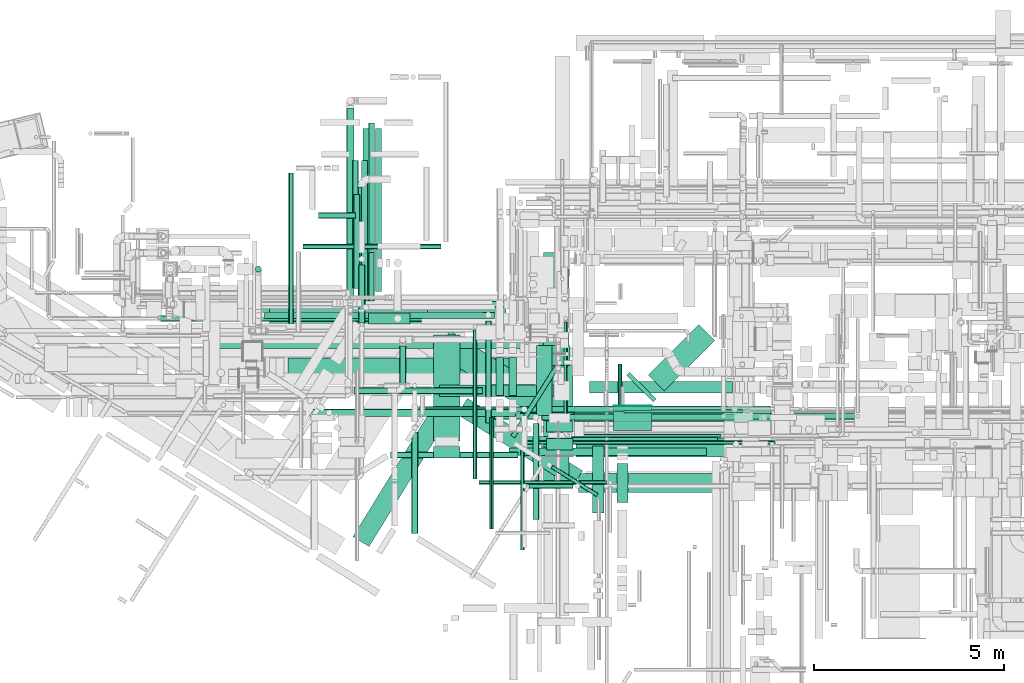
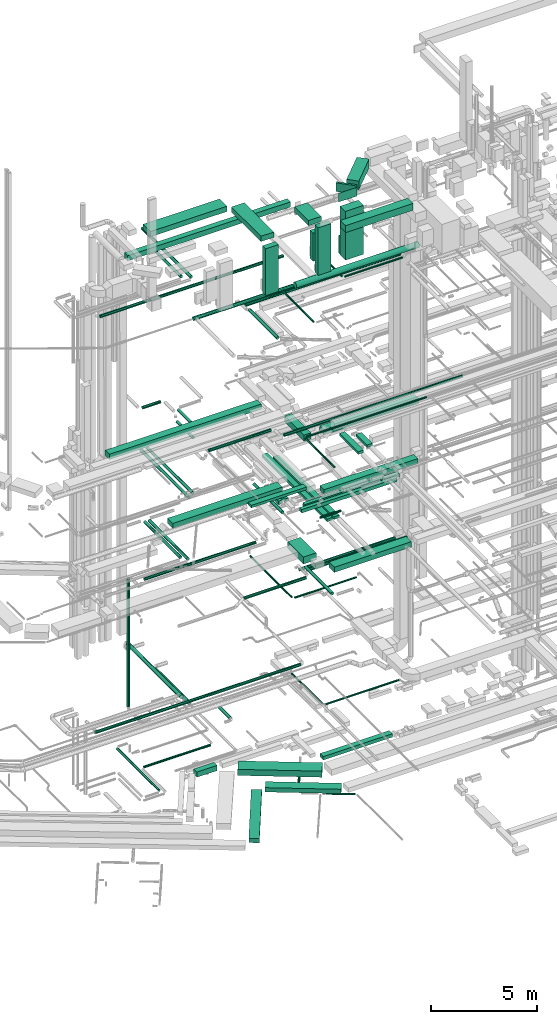
# One storey, part 28 of 337: 75 flow segments.
"""IFC2X3 building model written with IfcOpenShell, lengths in millimetres."""

from ifc_helpers import new_model, entity, si_unit, converted_unit, derived_unit, direction, frame, origin, origin_2d_with_axis, place, context, subcontext, project, spatial, rectangle, circle, extrude, type_object, element, save


model = new_model("IFC2X3")

# Units and contexts
model_context = context("Model", 3, precision=0.01, world=origin(), true_north=direction((6.12303176911189e-17, 1.0)))
body_context = subcontext(model_context, "Body", "Model", "MODEL_VIEW")
ifc_project = project(units=[si_unit("LENGTHUNIT", "METRE", prefix="MILLI"), si_unit("AREAUNIT", "SQUARE_METRE"), si_unit("VOLUMEUNIT", "CUBIC_METRE"), converted_unit("PLANEANGLEUNIT", "DEGREE", entity("IfcRatioMeasure", 0.0174532925199433), si_unit("PLANEANGLEUNIT", "RADIAN"), dimensions=[0, 0, 0, 0, 0, 0, 0]), si_unit("MASSUNIT", "GRAM", prefix="KILO"), derived_unit("MASSDENSITYUNIT", [(si_unit("MASSUNIT", "GRAM", prefix="KILO"), 1), (si_unit("LENGTHUNIT", "METRE"), -3)]), derived_unit("MOMENTOFINERTIAUNIT", [(si_unit("LENGTHUNIT", "METRE"), 4)]), si_unit("TIMEUNIT", "SECOND"), si_unit("FREQUENCYUNIT", "HERTZ"), si_unit("THERMODYNAMICTEMPERATUREUNIT", "DEGREE_CELSIUS"), derived_unit("THERMALTRANSMITTANCEUNIT", [(si_unit("MASSUNIT", "GRAM", prefix="KILO"), 1), (si_unit("THERMODYNAMICTEMPERATUREUNIT", "KELVIN"), -1), (si_unit("TIMEUNIT", "SECOND"), -3)]), derived_unit("VOLUMETRICFLOWRATEUNIT", [(si_unit("LENGTHUNIT", "METRE"), 3), (si_unit("TIMEUNIT", "SECOND"), -1)]), derived_unit("MASSFLOWRATEUNIT", [(si_unit("MASSUNIT", "GRAM", prefix="KILO"), 1), (si_unit("TIMEUNIT", "SECOND"), -1)]), derived_unit("ROTATIONALFREQUENCYUNIT", [(si_unit("TIMEUNIT", "SECOND"), -1)]), si_unit("ELECTRICCURRENTUNIT", "AMPERE"), si_unit("ELECTRICVOLTAGEUNIT", "VOLT"), si_unit("POWERUNIT", "WATT"), si_unit("FORCEUNIT", "NEWTON", prefix="KILO"), si_unit("ILLUMINANCEUNIT", "LUX"), si_unit("LUMINOUSFLUXUNIT", "LUMEN"), si_unit("LUMINOUSINTENSITYUNIT", "CANDELA"), derived_unit("USERDEFINED", [(si_unit("MASSUNIT", "GRAM", prefix="KILO"), -1), (si_unit("LENGTHUNIT", "METRE"), -2), (si_unit("TIMEUNIT", "SECOND"), 3), (si_unit("LUMINOUSFLUXUNIT", "LUMEN"), 1)]), derived_unit("LINEARVELOCITYUNIT", [(si_unit("LENGTHUNIT", "METRE"), 1), (si_unit("TIMEUNIT", "SECOND"), -1)]), si_unit("PRESSUREUNIT", "PASCAL"), derived_unit("USERDEFINED", [(si_unit("LENGTHUNIT", "METRE"), -2), (si_unit("MASSUNIT", "GRAM", prefix="KILO"), 1), (si_unit("TIMEUNIT", "SECOND"), -2)]), derived_unit("LINEARFORCEUNIT", [(si_unit("MASSUNIT", "GRAM", prefix="KILO"), 1), (si_unit("LENGTHUNIT", "METRE"), 1), (si_unit("TIMEUNIT", "SECOND"), -2), (si_unit("LENGTHUNIT", "METRE"), -1)]), derived_unit("PLANARFORCEUNIT", [(si_unit("MASSUNIT", "GRAM", prefix="KILO"), 1), (si_unit("LENGTHUNIT", "METRE"), 1), (si_unit("TIMEUNIT", "SECOND"), -2), (si_unit("LENGTHUNIT", "METRE"), -2)])], contexts=[model_context])

# Site, building, storey
site_placement = place(None, origin())
site = spatial("IfcSite", under=ifc_project, at=site_placement, CompositionType="ELEMENT")
building_placement = place(site_placement, origin())
building = spatial("IfcBuilding", under=site, at=building_placement, CompositionType="ELEMENT")
storey_placement = place(building_placement, origin())
storey = spatial("IfcBuildingStorey", under=building, at=storey_placement, CompositionType="ELEMENT", Elevation=0.0)

# Flow segments
duct_segment_type_1 = type_object("IfcDuctSegmentType", PredefinedType="NOTDEFINED")
flow_segment_1_placement = place(storey_placement, frame((15204.03, 9600.54, -800.0)))
element("IfcFlowSegment", 1, at=flow_segment_1_placement, inside=storey, type_object=duct_segment_type_1, context=body_context, shape_type="SweptSolid", body=[
    extrude(rectangle(XDim=3972.83667806784, YDim=700.0, at=origin_2d_with_axis()), frame((1867.74, 1354.02, 0.0), z_axis=(0.0, 0.0, 1.0), x_axis=(-0.84642893008142, 0.532501705463206, 0.0)), (0.0, 0.0, 1.0), 350.0),
])
flow_segment_2_placement = place(storey_placement, frame((13426.2, 12483.83, -750.0)))
element("IfcFlowSegment", 2, at=flow_segment_2_placement, inside=storey, type_object=duct_segment_type_1, context=body_context, shape_type="SweptSolid", body=[
    extrude(rectangle(XDim=1097.78533008796, YDim=300.000000000001, at=origin_2d_with_axis()), frame((548.9, 150.02, 0.0)), (0.0, 0.0, 1.0), 300.0),
])
flow_segment_3_placement = place(storey_placement, frame((15769.81, 8199.71, -975.0)))
element("IfcFlowSegment", 3, at=flow_segment_3_placement, inside=storey, type_object=duct_segment_type_1, context=body_context, shape_type="SweptSolid", body=[
    extrude(rectangle(XDim=3583.77962437014, YDim=500.000000000001, at=origin_2d_with_axis()), frame((1649.83, 1165.79, 0.0), z_axis=(0.0, 0.0, 1.0), x_axis=(-0.846428930081417, 0.532501705463211, 0.0)), (0.0, 0.0, 1.0), 250.0),
])
flow_segment_4_placement = place(storey_placement, frame((18041.81, 10437.88, 11150.0)))
element("IfcFlowSegment", 4, at=flow_segment_4_placement, inside=storey, type_object=duct_segment_type_1, context=body_context, shape_type="SweptSolid", body=[
    extrude(rectangle(XDim=1480.0000000004, YDim=700.000000000001, at=origin_2d_with_axis()), frame((350.0, 740.0, 0.0), z_axis=(0.0, 0.0, 1.0), x_axis=(0.0, -1.0, 0.0)), (0.0, 0.0, 1.0), 400.0),
])
flow_segment_5_placement = place(storey_placement, frame((18891.81, 8987.88, 11250.0)))
element("IfcFlowSegment", 5, at=flow_segment_5_placement, inside=storey, type_object=duct_segment_type_1, context=body_context, shape_type="SweptSolid", body=[
    extrude(rectangle(XDim=4200.00000000013, YDim=500.0, at=origin_2d_with_axis()), frame((2100.0, 250.0, 0.0)), (0.0, 0.0, 1.0), 300.000000000001),
])
flow_segment_6_placement = place(storey_placement, frame((18870.0, 9924.94, 15150.0)))
element("IfcFlowSegment", 6, at=flow_segment_6_placement, inside=storey, type_object=duct_segment_type_1, context=body_context, shape_type="SweptSolid", body=[
    extrude(rectangle(XDim=5109.29869136261, YDim=400.0, at=origin_2d_with_axis()), frame((2554.65, 200.0, 0.0)), (0.0, 0.0, 1.0), 300.000000000001),
])
flow_segment_7_placement = place(storey_placement, frame((15292.89, 10584.63, 15250.0)))
element("IfcFlowSegment", 7, at=flow_segment_7_placement, inside=storey, type_object=duct_segment_type_1, context=body_context, shape_type="SweptSolid", body=[
    extrude(rectangle(XDim=3007.10674455727, YDim=300.000000000001, at=origin_2d_with_axis()), frame((1503.55, 150.0, 0.0)), (0.0, 0.0, 1.0), 150.000000000001),
])
flow_segment_8_placement = place(storey_placement, frame((18044.75, 8212.59, 14925.0)))
element("IfcFlowSegment", 8, at=flow_segment_8_placement, inside=storey, type_object=duct_segment_type_1, context=body_context, shape_type="SweptSolid", body=[
    extrude(rectangle(XDim=6156.31853855022, YDim=300.000000000001, at=origin_2d_with_axis()), frame((150.0, 3078.16, 0.0), z_axis=(0.0, 0.0, 1.0), x_axis=(0.0, -1.0, 0.0)), (0.0, 0.0, 1.0), 150.000000000001),
])
flow_segment_9_placement = place(storey_placement, frame((18416.63, 8215.15, 14925.0)))
element("IfcFlowSegment", 9, at=flow_segment_9_placement, inside=storey, type_object=duct_segment_type_1, context=body_context, shape_type="SweptSolid", body=[
    extrude(rectangle(XDim=5728.76050698935, YDim=299.999999999999, at=origin_2d_with_axis()), frame((150.0, 2864.38, 0.0), z_axis=(0.0, 0.0, 1.0), x_axis=(0.0, 1.0, 0.0)), (0.0, 0.0, 1.0), 150.000000000001),
])
flow_segment_10_placement = place(storey_placement, frame((8774.52, 12678.06, 19050.0)))
element("IfcFlowSegment", 10, at=flow_segment_10_placement, inside=storey, type_object=duct_segment_type_1, context=body_context, shape_type="SweptSolid", body=[
    extrude(rectangle(XDim=8275.73593128809, YDim=400.0, at=origin_2d_with_axis()), frame((4137.87, 200.0, 0.0), z_axis=(0.0, 0.0, 1.0), x_axis=(-1.0, 0.0, 0.0)), (0.0, 0.0, 1.0), 300.000000000001),
])
flow_segment_11_placement = place(storey_placement, frame((17859.23, 10075.31, 18500.0)))
element("IfcFlowSegment", 11, at=flow_segment_11_placement, inside=storey, type_object=duct_segment_type_1, context=body_context, shape_type="SweptSolid", body=[
    extrude(rectangle(XDim=1842.09999999976, YDim=400.0, at=origin_2d_with_axis()), frame((200.0, 921.05, 0.0), z_axis=(0.0, 0.0, 1.0), x_axis=(0.0, -1.0, 0.0)), (0.0, 0.0, 1.0), 349.999999999998),
])
flow_segment_12_placement = place(storey_placement, frame((19970.04, 7790.46, 18775.0)))
element("IfcFlowSegment", 12, at=flow_segment_12_placement, inside=storey, type_object=duct_segment_type_1, context=body_context, shape_type="SweptSolid", body=[
    extrude(rectangle(XDim=1026.9595086912, YDim=300.000000000001, at=origin_2d_with_axis()), frame((150.0, 513.48, 0.0), z_axis=(0.0, 0.0, 1.0), x_axis=(0.0, -1.0, 0.0)), (0.0, 0.0, 1.0), 150.000000000001),
])
flow_segment_13_placement = place(storey_placement, frame((18849.92, 9925.3, 18600.0)))
element("IfcFlowSegment", 13, at=flow_segment_13_placement, inside=storey, type_object=duct_segment_type_1, context=body_context, shape_type="SweptSolid", body=[
    extrude(rectangle(XDim=5165.62500000007, YDim=400.0, at=origin_2d_with_axis()), frame((2582.81, 200.0, 0.0)), (0.0, 0.0, 1.0), 300.000000000001),
])
flow_segment_14_placement = place(storey_placement, frame((17480.0, 9320.0, 15250.0)))
element("IfcFlowSegment", 14, at=flow_segment_14_placement, inside=storey, type_object=duct_segment_type_1, context=body_context, shape_type="SweptSolid", body=[
    extrude(rectangle(XDim=5147.55337189572, YDim=200.0, at=origin_2d_with_axis()), frame((2573.78, 100.0, 0.0), z_axis=(0.0, 0.0, 1.0), x_axis=(-1.0, 0.0, 0.0)), (0.0, 0.0, 1.0), 200.000000000002),
])
flow_segment_15_placement = place(storey_placement, frame((17134.94, 9028.26, 15250.0)))
element("IfcFlowSegment", 15, at=flow_segment_15_placement, inside=storey, type_object=duct_segment_type_1, context=body_context, shape_type="SweptSolid", body=[
    extrude(rectangle(XDim=5197.61846850479, YDim=200.0, at=origin_2d_with_axis()), frame((2598.81, 100.0, 0.0), z_axis=(0.0, 0.0, 1.0), x_axis=(-1.0, 0.0, 0.0)), (0.0, 0.0, 1.0), 200.000000000002),
])
flow_segment_16_placement = place(storey_placement, frame((19331.36, 7509.06, 18780.0)))
element("IfcFlowSegment", 16, at=flow_segment_16_placement, inside=storey, type_object=duct_segment_type_1, context=body_context, shape_type="SweptSolid", body=[
    extrude(rectangle(XDim=1766.02500000003, YDim=300.000000000001, at=origin_2d_with_axis()), frame((150.0, 883.01, 0.0), z_axis=(0.0, 0.0, 1.0), x_axis=(0.0, -1.0, 0.0)), (0.0, 0.0, 1.0), 150.000000000001),
])
flow_segment_17_placement = place(storey_placement, frame((11309.44, 11089.53, 15150.0)))
element("IfcFlowSegment", 17, at=flow_segment_17_placement, inside=storey, type_object=duct_segment_type_1, context=body_context, shape_type="SweptSolid", body=[
    extrude(rectangle(XDim=5965.56086231066, YDim=499.999999999999, at=origin_2d_with_axis()), frame((2982.78, 250.0, 0.0)), (0.0, 0.0, 1.0), 300.000000000001),
])
flow_segment_18_placement = place(storey_placement, frame((17130.0, 10607.55, 14900.0)))
element("IfcFlowSegment", 18, at=flow_segment_18_placement, inside=storey, type_object=duct_segment_type_1, context=body_context, shape_type="SweptSolid", body=[
    extrude(rectangle(XDim=997.150594281624, YDim=200.0, at=origin_2d_with_axis()), frame((100.0, 498.58, 0.0), z_axis=(0.0, 0.0, 1.0), x_axis=(0.0, -1.0, 0.0)), (0.0, 0.0, 1.0), 200.000000000002),
])
flow_segment_19_placement = place(storey_placement, frame((16784.94, 10611.81, 14900.0)))
element("IfcFlowSegment", 19, at=flow_segment_19_placement, inside=storey, type_object=duct_segment_type_1, context=body_context, shape_type="SweptSolid", body=[
    extrude(rectangle(XDim=992.893231441465, YDim=200.0, at=origin_2d_with_axis()), frame((100.0, 496.45, 0.0), z_axis=(0.0, 0.0, 1.0), x_axis=(0.0, -1.0, 0.0)), (0.0, 0.0, 1.0), 200.000000000002),
])
flow_segment_20_placement = place(storey_placement, frame((13017.82, 6624.99, -975.0)))
element("IfcFlowSegment", 20, at=flow_segment_20_placement, inside=storey, type_object=duct_segment_type_1, context=body_context, shape_type="SweptSolid", body=[
    extrude(rectangle(XDim=4035.85371403088, YDim=500.0, at=origin_2d_with_axis()), frame((1272.23, 1848.69, 0.0), z_axis=(0.0, 0.0, 1.0), x_axis=(0.525021755454614, 0.851088806352989, 0.0)), (0.0, 0.0, 1.0), 250.0),
])
flow_segment_21_placement = place(storey_placement, frame((19255.54, 10670.0, -700.0)))
element("IfcFlowSegment", 21, at=flow_segment_21_placement, inside=storey, type_object=duct_segment_type_1, context=body_context, shape_type="SweptSolid", body=[
    extrude(rectangle(XDim=3767.66742285411, YDim=300.000000000001, at=origin_2d_with_axis()), frame((1883.83, 150.0, 0.0)), (0.0, 0.0, 1.0), 200.0),
])
duct_segment_type_2 = type_object("IfcDuctSegmentType", PredefinedType="NOTDEFINED")
flow_segment_22_placement = place(storey_placement, frame((17176.46, 9485.25, -1164.1)))
element("IfcFlowSegment", 22, at=flow_segment_22_placement, inside=storey, type_object=duct_segment_type_2, context=body_context, shape_type="SweptSolid", body=[
    extrude(circle(Radius=62.5, at=origin_2d_with_axis()), frame((54.5, 34.88, 64.1), z_axis=(0.532501705463204, 0.846428930081421, 0.0), x_axis=(-0.846428930081421, 0.532501705463204, 0.0)), (0.0, 0.0, 1.0), 2181.26326903953),
])
flow_segment_23_placement = place(storey_placement, frame((18237.11, 7937.9, -1151.6)))
element("IfcFlowSegment", 23, at=flow_segment_23_placement, inside=storey, type_object=duct_segment_type_2, context=body_context, shape_type="SweptSolid", body=[
    extrude(circle(Radius=50.0, at=origin_2d_with_axis()), frame((1218.92, 44.0, 51.6), z_axis=(-0.84804809615643, 0.529919264233199, 0.0), x_axis=(-0.529919264233199, -0.84804809615643, 0.0)), (0.0, 0.0, 1.0), 1404.20361417074),
])
flow_segment_24_placement = place(storey_placement, frame((11324.49, 12500.75, -864.1)))
element("IfcFlowSegment", 24, at=flow_segment_24_placement, inside=storey, type_object=duct_segment_type_2, context=body_context, shape_type="SweptSolid", body=[
    extrude(circle(Radius=62.5, at=origin_2d_with_axis()), frame((64.1, 0.0, 64.1), z_axis=(0.0, 1.0, 0.0), x_axis=(1.0, 0.0, 0.0)), (0.0, 0.0, 1.0), 3972.29665),
])
flow_segment_25_placement = place(storey_placement, frame((11708.09, 14465.53, -864.1)))
element("IfcFlowSegment", 25, at=flow_segment_25_placement, inside=storey, type_object=duct_segment_type_2, context=body_context, shape_type="SweptSolid", body=[
    extrude(circle(Radius=62.5, at=origin_2d_with_axis()), frame((0.0, 64.1, 64.1), z_axis=(1.0, 0.0, 0.0), x_axis=(0.0, -1.0, 0.0)), (0.0, 0.0, 1.0), 3636.54474999999),
])
flow_segment_26_placement = place(storey_placement, frame((17692.76, 10159.92, 10983.4)))
element("IfcFlowSegment", 26, at=flow_segment_26_placement, inside=storey, type_object=duct_segment_type_2, context=body_context, shape_type="SweptSolid", body=[
    extrude(circle(Radius=80.0, at=origin_2d_with_axis()), frame((0.0, 81.6, 81.6), z_axis=(1.0, 0.0, 0.0), x_axis=(0.0, 1.0, 0.0)), (0.0, 0.0, 1.0), 5224.54407601142),
])
flow_segment_27_placement = place(storey_placement, frame((14006.66, 8959.92, 11368.4)))
element("IfcFlowSegment", 27, at=flow_segment_27_placement, inside=storey, type_object=duct_segment_type_2, context=body_context, shape_type="SweptSolid", body=[
    extrude(circle(Radius=80.0, at=origin_2d_with_axis()), frame((0.0, 81.6, 81.6), z_axis=(1.0, 0.0, 0.0), x_axis=(0.0, -1.0, 0.0)), (0.0, 0.0, 1.0), 3366.09397595534),
])
flow_segment_28_placement = place(storey_placement, frame((17754.62, 7341.69, 11318.4)))
element("IfcFlowSegment", 28, at=flow_segment_28_placement, inside=storey, type_object=duct_segment_type_2, context=body_context, shape_type="SweptSolid", body=[
    extrude(circle(Radius=80.0, at=origin_2d_with_axis()), frame((81.6, 0.0, 81.6), z_axis=(0.0, 1.0, 0.0), x_axis=(1.0, 0.0, 0.0)), (0.0, 0.0, 1.0), 2525.00000000002),
])
flow_segment_29_placement = place(storey_placement, frame((10443.31, 13854.91, 3480.0)))
element("IfcFlowSegment", 29, at=flow_segment_29_placement, inside=storey, type_object=duct_segment_type_2, context=body_context, shape_type="SweptSolid", body=[
    extrude(circle(Radius=80.0, at=origin_2d_with_axis()), frame((81.6, 81.6, 0.0), z_axis=(0.0, 0.0, 1.0), x_axis=(-1.0, 0.0, 0.0)), (0.0, 0.0, 1.0), 7360.00000000002),
])
flow_segment_30_placement = place(storey_placement, frame((16337.59, 8258.87, 11048.4)))
element("IfcFlowSegment", 30, at=flow_segment_30_placement, inside=storey, type_object=duct_segment_type_2, context=body_context, shape_type="SweptSolid", body=[
    extrude(circle(Radius=50.0, at=origin_2d_with_axis()), frame((0.0, 51.6, 51.6), z_axis=(1.0, 0.0, 0.0), x_axis=(0.0, 1.0, 0.0)), (0.0, 0.0, 1.0), 3362.52257293551),
])
flow_segment_31_placement = place(storey_placement, frame((16185.99, 8410.47, 11048.4)))
element("IfcFlowSegment", 31, at=flow_segment_31_placement, inside=storey, type_object=duct_segment_type_2, context=body_context, shape_type="SweptSolid", body=[
    extrude(circle(Radius=50.0, at=origin_2d_with_axis()), frame((51.6, 0.0, 51.6), z_axis=(0.0, 1.0, 0.0), x_axis=(1.0, 0.0, 0.0)), (0.0, 0.0, 1.0), 3915.21893185858),
])
flow_segment_32_placement = place(storey_placement, frame((13241.97, 13146.64, 11368.4)))
element("IfcFlowSegment", 32, at=flow_segment_32_placement, inside=storey, type_object=duct_segment_type_2, context=body_context, shape_type="SweptSolid", body=[
    extrude(circle(Radius=80.0, at=origin_2d_with_axis()), frame((81.6, 0.0, 81.6), z_axis=(0.0, 1.0, 0.0), x_axis=(1.0, 0.0, 0.0)), (0.0, 0.0, 1.0), 3650.0),
])
flow_segment_33_placement = place(storey_placement, frame((13001.97, 13440.27, 11368.4)))
element("IfcFlowSegment", 33, at=flow_segment_33_placement, inside=storey, type_object=duct_segment_type_2, context=body_context, shape_type="SweptSolid", body=[
    extrude(circle(Radius=80.0, at=origin_2d_with_axis()), frame((81.6, 0.0, 81.6), z_axis=(0.0, 1.0, 0.0), x_axis=(1.0, 0.0, 0.0)), (0.0, 0.0, 1.0), 3360.00000000002),
])
flow_segment_34_placement = place(storey_placement, frame((12847.57, 13115.88, 3558.4)))
element("IfcFlowSegment", 34, at=flow_segment_34_placement, inside=storey, type_object=duct_segment_type_2, context=body_context, shape_type="SweptSolid", body=[
    extrude(circle(Radius=100.0, at=origin_2d_with_axis()), frame((101.6, 0.0, 101.6), z_axis=(0.0, 1.0, 0.0), x_axis=(-1.0, 0.0, 0.0)), (0.0, 0.0, 1.0), 5057.50000000003),
])
flow_segment_35_placement = place(storey_placement, frame((13145.04, 12874.84, 3235.9)))
element("IfcFlowSegment", 35, at=flow_segment_35_placement, inside=storey, type_object=duct_segment_type_2, context=body_context, shape_type="SweptSolid", body=[
    extrude(circle(Radius=100.0, at=origin_2d_with_axis()), frame((101.6, 0.0, 101.6), z_axis=(0.0, 1.0, 0.0), x_axis=(-1.0, 0.0, 0.0)), (0.0, 0.0, 1.0), 3228.75000000011),
])
flow_segment_36_placement = place(storey_placement, frame((7949.69, 12556.23, 3568.4)))
element("IfcFlowSegment", 36, at=flow_segment_36_placement, inside=storey, type_object=duct_segment_type_2, context=body_context, shape_type="SweptSolid", body=[
    extrude(circle(Radius=80.0, at=origin_2d_with_axis()), frame((0.0, 81.6, 81.6), z_axis=(1.0, 0.0, 0.0), x_axis=(0.0, -1.0, 0.0)), (0.0, 0.0, 1.0), 11195.0000000001),
])
flow_segment_37_placement = place(storey_placement, frame((18571.85, 9643.58, 3328.4)))
element("IfcFlowSegment", 37, at=flow_segment_37_placement, inside=storey, type_object=duct_segment_type_2, context=body_context, shape_type="SweptSolid", body=[
    extrude(circle(Radius=50.0, at=origin_2d_with_axis()), frame((51.6, 0.0, 51.6), z_axis=(0.0, 1.0, 0.0), x_axis=(1.0, 0.0, 0.0)), (0.0, 0.0, 1.0), 2894.25000000004),
])
flow_segment_38_placement = place(storey_placement, frame((13611.02, 13350.0, 14918.4)))
element("IfcFlowSegment", 38, at=flow_segment_38_placement, inside=storey, type_object=duct_segment_type_2, context=body_context, shape_type="SweptSolid", body=[
    extrude(circle(Radius=80.0, at=origin_2d_with_axis()), frame((81.6, 0.0, 81.6), z_axis=(0.0, 1.0, 0.0), x_axis=(1.0, 0.0, 0.0)), (0.0, 0.0, 1.0), 4288.83069074388),
])
flow_segment_39_placement = place(storey_placement, frame((13429.37, 13098.06, 19138.4)))
element("IfcFlowSegment", 39, at=flow_segment_39_placement, inside=storey, type_object=duct_segment_type_2, context=body_context, shape_type="SweptSolid", body=[
    extrude(circle(Radius=80.0, at=origin_2d_with_axis()), frame((81.6, 0.0, 81.6), z_axis=(0.0, 1.0, 0.0), x_axis=(-1.0, 0.0, 0.0)), (0.0, 0.0, 1.0), 1274.81299614427),
])
flow_segment_40_placement = place(storey_placement, frame((12112.22, 15263.22, 19168.4)))
element("IfcFlowSegment", 40, at=flow_segment_40_placement, inside=storey, type_object=duct_segment_type_2, context=body_context, shape_type="SweptSolid", body=[
    extrude(circle(Radius=80.0, at=origin_2d_with_axis()), frame((0.0, 81.6, 81.6), z_axis=(1.0, 0.0, 0.0), x_axis=(0.0, 1.0, 0.0)), (0.0, 0.0, 1.0), 978.750000000011),
])
flow_segment_41_placement = place(storey_placement, frame((13049.69, 10650.21, 19168.4)))
element("IfcFlowSegment", 41, at=flow_segment_41_placement, inside=storey, type_object=duct_segment_type_2, context=body_context, shape_type="SweptSolid", body=[
    extrude(circle(Radius=80.0, at=origin_2d_with_axis()), frame((0.0, 81.6, 81.6), z_axis=(1.0, 0.0, 0.0), x_axis=(0.0, -1.0, 0.0)), (0.0, 0.0, 1.0), 3380.31250000003),
])
flow_segment_42_placement = place(storey_placement, frame((17438.24, 6540.12, 19223.4)))
element("IfcFlowSegment", 42, at=flow_segment_42_placement, inside=storey, type_object=duct_segment_type_2, context=body_context, shape_type="SweptSolid", body=[
    extrude(circle(Radius=50.0, at=origin_2d_with_axis()), frame((51.6, 0.0, 51.6), z_axis=(0.0, 1.0, 0.0), x_axis=(-1.0, 0.0, 0.0)), (0.0, 0.0, 1.0), 2730.00000000001),
])
flow_segment_43_placement = place(storey_placement, frame((17589.84, 9318.52, 19223.4)))
element("IfcFlowSegment", 43, at=flow_segment_43_placement, inside=storey, type_object=duct_segment_type_2, context=body_context, shape_type="SweptSolid", body=[
    extrude(circle(Radius=50.0, at=origin_2d_with_axis()), frame((0.0, 51.6, 51.6), z_axis=(1.0, 0.0, 0.0), x_axis=(0.0, -1.0, 0.0)), (0.0, 0.0, 1.0), 6535.00000000003),
])
flow_segment_44_placement = place(storey_placement, frame((10684.9, 12632.75, 11388.41)))
element("IfcFlowSegment", 44, at=flow_segment_44_placement, inside=storey, type_object=duct_segment_type_2, context=body_context, shape_type="SweptSolid", body=[
    extrude(circle(Radius=80.0, at=origin_2d_with_axis()), frame((0.0, 81.6, 81.6), z_axis=(1.0, 0.0, 0.0), x_axis=(0.0, 1.0, 0.0)), (0.0, 0.0, 1.0), 6066.43176407138),
])
flow_segment_45_placement = place(storey_placement, frame((17996.21, 9945.1, 10983.4)))
element("IfcFlowSegment", 45, at=flow_segment_45_placement, inside=storey, type_object=duct_segment_type_2, context=body_context, shape_type="SweptSolid", body=[
    extrude(circle(Radius=80.0, at=origin_2d_with_axis()), frame((0.0, 81.6, 81.6), z_axis=(1.0, 0.0, 0.0), x_axis=(0.0, -1.0, 0.0)), (0.0, 0.0, 1.0), 5440.70055744883),
])
flow_segment_46_placement = place(storey_placement, frame((17660.56, 8155.54, 15235.9)))
element("IfcFlowSegment", 46, at=flow_segment_46_placement, inside=storey, type_object=duct_segment_type_2, context=body_context, shape_type="SweptSolid", body=[
    extrude(circle(Radius=62.5, at=origin_2d_with_axis()), frame((0.0, 64.1, 64.1), z_axis=(1.0, 0.0, 0.0), x_axis=(0.0, 1.0, 0.0)), (0.0, 0.0, 1.0), 1150.00000000002),
])
flow_segment_47_placement = place(storey_placement, frame((16505.63, 9875.69, 14888.4)))
element("IfcFlowSegment", 47, at=flow_segment_47_placement, inside=storey, type_object=duct_segment_type_2, context=body_context, shape_type="SweptSolid", body=[
    extrude(circle(Radius=80.0, at=origin_2d_with_axis()), frame((81.6, 0.0, 81.6), z_axis=(0.0, 1.0, 0.0), x_axis=(1.0, 0.0, 0.0)), (0.0, 0.0, 1.0), 2690.00000000006),
])
flow_segment_48_placement = place(storey_placement, frame((13169.37, 12519.81, 18753.4)))
element("IfcFlowSegment", 48, at=flow_segment_48_placement, inside=storey, type_object=duct_segment_type_2, context=body_context, shape_type="SweptSolid", body=[
    extrude(circle(Radius=80.0, at=origin_2d_with_axis()), frame((81.6, 0.0, 81.6), z_axis=(0.0, 1.0, 0.0), x_axis=(-1.0, 0.0, 0.0)), (0.0, 0.0, 1.0), 1520.00000000002),
])
flow_segment_49_placement = place(storey_placement, frame((16750.01, 9975.52, 19168.4)))
element("IfcFlowSegment", 49, at=flow_segment_49_placement, inside=storey, type_object=duct_segment_type_2, context=body_context, shape_type="SweptSolid", body=[
    extrude(circle(Radius=80.0, at=origin_2d_with_axis()), frame((0.0, 81.6, 81.6), z_axis=(1.0, 0.0, 0.0), x_axis=(0.0, 1.0, 0.0)), (0.0, 0.0, 1.0), 9719.68750000001),
])
flow_segment_50_placement = place(storey_placement, frame((13277.81, 13090.0, 14918.4)))
element("IfcFlowSegment", 50, at=flow_segment_50_placement, inside=storey, type_object=duct_segment_type_2, context=body_context, shape_type="SweptSolid", body=[
    extrude(circle(Radius=80.0, at=origin_2d_with_axis()), frame((81.6, 0.0, 81.6), z_axis=(0.0, 1.0, 0.0), x_axis=(-1.0, 0.0, 0.0)), (0.0, 0.0, 1.0), 4548.83069074375),
])
flow_segment_51_placement = place(storey_placement, frame((13430.59, 13169.26, 27518.4)))
element("IfcFlowSegment", 51, at=flow_segment_51_placement, inside=storey, type_object=duct_segment_type_2, context=body_context, shape_type="SweptSolid", body=[
    extrude(circle(Radius=80.0, at=origin_2d_with_axis()), frame((81.6, 0.0, 81.6), z_axis=(0.0, 1.0, 0.0), x_axis=(1.0, 0.0, 0.0)), (0.0, 0.0, 1.0), 4621.1333543546),
])
flow_segment_52_placement = place(storey_placement, frame((13037.84, 13429.96, 27518.4)))
element("IfcFlowSegment", 52, at=flow_segment_52_placement, inside=storey, type_object=duct_segment_type_2, context=body_context, shape_type="SweptSolid", body=[
    extrude(circle(Radius=80.0, at=origin_2d_with_axis()), frame((81.6, 0.0, 81.6), z_axis=(0.0, 1.0, 0.0), x_axis=(1.0, 0.0, 0.0)), (0.0, 0.0, 1.0), 2474.50000000001),
])
flow_segment_53_placement = place(storey_placement, frame((8445.97, 12927.67, 27118.4)))
element("IfcFlowSegment", 53, at=flow_segment_53_placement, inside=storey, type_object=duct_segment_type_2, context=body_context, shape_type="SweptSolid", body=[
    extrude(circle(Radius=80.0, at=origin_2d_with_axis()), frame((0.0, 81.6, 81.6), z_axis=(1.0, 0.0, 0.0), x_axis=(0.0, 1.0, 0.0)), (0.0, 0.0, 1.0), 9985.76490128746),
])
flow_segment_54_placement = place(storey_placement, frame((11874.94, 10045.53, 27498.4)))
element("IfcFlowSegment", 54, at=flow_segment_54_placement, inside=storey, type_object=duct_segment_type_2, context=body_context, shape_type="SweptSolid", body=[
    extrude(circle(Radius=100.0, at=origin_2d_with_axis()), frame((0.0, 101.6, 101.6), z_axis=(1.0, 0.0, 0.0), x_axis=(0.0, 1.0, 0.0)), (0.0, 0.0, 1.0), 5424.99999999999),
])
flow_segment_55_placement = place(storey_placement, frame((17414.94, 9988.03, 27440.9)))
element("IfcFlowSegment", 55, at=flow_segment_55_placement, inside=storey, type_object=duct_segment_type_2, context=body_context, shape_type="SweptSolid", body=[
    extrude(circle(Radius=157.5, at=origin_2d_with_axis()), frame((0.0, 159.1, 159.1), z_axis=(1.0, 0.0, 0.0), x_axis=(0.0, 1.0, 0.0)), (0.0, 0.0, 1.0), 6698.39826326098),
])
flow_segment_56_placement = place(storey_placement, frame((16617.59, 7087.13, 27548.4)))
element("IfcFlowSegment", 56, at=flow_segment_56_placement, inside=storey, type_object=duct_segment_type_2, context=body_context, shape_type="SweptSolid", body=[
    extrude(circle(Radius=50.0, at=origin_2d_with_axis()), frame((51.6, 0.0, 51.6), z_axis=(0.0, 1.0, 0.0), x_axis=(-1.0, 0.0, 0.0)), (0.0, 0.0, 1.0), 2940.0),
])
flow_segment_57_placement = place(storey_placement, frame((14747.42, 10152.2, 27238.4)))
element("IfcFlowSegment", 57, at=flow_segment_57_placement, inside=storey, type_object=duct_segment_type_2, context=body_context, shape_type="SweptSolid", body=[
    extrude(circle(Radius=80.0, at=origin_2d_with_axis()), frame((0.0, 81.6, 81.6), z_axis=(1.0, 0.0, 0.0), x_axis=(0.0, 1.0, 0.0)), (0.0, 0.0, 1.0), 8454.99999999995),
])
flow_segment_58_placement = place(storey_placement, frame((20004.13, 10299.94, 27048.4)))
element("IfcFlowSegment", 58, at=flow_segment_58_placement, inside=storey, type_object=duct_segment_type_2, context=body_context, shape_type="SweptSolid", body=[
    extrude(circle(Radius=50.0, at=origin_2d_with_axis()), frame((51.6, 0.0, 51.6), z_axis=(0.0, 1.0, 0.0), x_axis=(1.0, 0.0, 0.0)), (0.0, 0.0, 1.0), 1131.60000000008),
])
flow_segment_59_placement = place(storey_placement, frame((18723.44, 9491.98, 3328.4)))
element("IfcFlowSegment", 59, at=flow_segment_59_placement, inside=storey, type_object=duct_segment_type_2, context=body_context, shape_type="SweptSolid", body=[
    extrude(circle(Radius=50.0, at=origin_2d_with_axis()), frame((0.0, 51.6, 51.6), z_axis=(1.0, 0.0, 0.0), x_axis=(0.0, -1.0, 0.0)), (0.0, 0.0, 1.0), 3998.57864376269),
])
flow_segment_60_placement = place(storey_placement, frame((20155.73, 10148.35, 27048.4)))
element("IfcFlowSegment", 60, at=flow_segment_60_placement, inside=storey, type_object=duct_segment_type_2, context=body_context, shape_type="SweptSolid", body=[
    extrude(circle(Radius=50.0, at=origin_2d_with_axis()), frame((0.0, 51.6, 51.6), z_axis=(1.0, 0.0, 0.0), x_axis=(0.0, -1.0, 0.0)), (0.0, 0.0, 1.0), 3139.2986437627),
])
flow_segment_61_placement = place(storey_placement, frame((14249.82, 10896.08, 3218.4)))
element("IfcFlowSegment", 61, at=flow_segment_61_placement, inside=storey, type_object=duct_segment_type_2, context=body_context, shape_type="SweptSolid", body=[
    extrude(circle(Radius=80.0, at=origin_2d_with_axis()), frame((81.6, 0.0, 81.6), z_axis=(0.0, 1.0, 0.0), x_axis=(1.0, 0.0, 0.0)), (0.0, 0.0, 1.0), 1018.46096908267),
])
flow_segment_62_placement = place(storey_placement, frame((14565.83, 6975.2, 27368.4)))
element("IfcFlowSegment", 62, at=flow_segment_62_placement, inside=storey, type_object=duct_segment_type_2, context=body_context, shape_type="SweptSolid", body=[
    extrude(circle(Radius=80.0, at=origin_2d_with_axis()), frame((81.6, 0.0, 81.6), z_axis=(0.0, 1.0, 0.0), x_axis=(1.0, 0.0, 0.0)), (0.0, 0.0, 1.0), 2664.65710450736),
])
duct_segment_type_3 = type_object("IfcDuctSegmentType", PredefinedType="NOTDEFINED")
flow_segment_63_placement = place(storey_placement, frame((15137.92, 8961.6, 28510.0)))
element("IfcFlowSegment", 63, at=flow_segment_63_placement, inside=storey, type_object=duct_segment_type_3, context=body_context, shape_type="SweptSolid", body=[
    extrude(rectangle(XDim=299.999999999998, YDim=699.999999999999, at=origin_2d_with_axis()), frame((350.0, 150.0, 0.0), z_axis=(0.0, 0.0, 1.0), x_axis=(0.0, -1.0, 0.0)), (0.0, 0.0, 1.0), 2690.0),
])
flow_segment_64_placement = place(storey_placement, frame((15137.92, 9411.6, 31350.0)))
element("IfcFlowSegment", 64, at=flow_segment_64_placement, inside=storey, type_object=duct_segment_type_3, context=body_context, shape_type="SweptSolid", body=[
    extrude(rectangle(XDim=2788.00430254043, YDim=699.999999999999, at=origin_2d_with_axis()), frame((350.0, 1394.0, 0.0), z_axis=(0.0, 0.0, 1.0), x_axis=(0.0, 1.0, 0.0)), (0.0, 0.0, 1.0), 300.000000000001),
])
flow_segment_65_placement = place(storey_placement, frame((10823.95, 12349.6, 31350.0)))
element("IfcFlowSegment", 65, at=flow_segment_65_placement, inside=storey, type_object=duct_segment_type_3, context=body_context, shape_type="SweptSolid", body=[
    extrude(rectangle(XDim=4163.97095500002, YDim=699.999999999999, at=origin_2d_with_axis()), frame((2081.99, 350.0, 0.0), z_axis=(0.0, 0.0, 1.0), x_axis=(-1.0, 0.0, 0.0)), (0.0, 0.0, 1.0), 300.000000000001),
])
flow_segment_66_placement = place(storey_placement, frame((18114.38, 9166.27, 28500.0)))
element("IfcFlowSegment", 66, at=flow_segment_66_placement, inside=storey, type_object=duct_segment_type_3, context=body_context, shape_type="SweptSolid", body=[
    extrude(rectangle(XDim=700.000000000001, YDim=300.0, at=origin_2d_with_axis()), frame((350.0, 150.0, 0.0), z_axis=(0.0, 0.0, 1.0), x_axis=(-1.0, 0.0, 0.0)), (0.0, 0.0, 1.0), 2749.99997499999),
])
flow_segment_67_placement = place(storey_placement, frame((18114.38, 9638.14, 29033.96)))
element("IfcFlowSegment", 67, at=flow_segment_67_placement, inside=storey, type_object=duct_segment_type_3, context=body_context, shape_type="SweptSolid", body=[
    extrude(rectangle(XDim=700.000000000001, YDim=300.0, at=origin_2d_with_axis()), frame((350.0, 150.0, 0.0)), (0.0, 0.0, 1.0), 1616.03557239339),
])
flow_segment_68_placement = place(storey_placement, frame((9288.91, 11849.6, 30800.0)))
element("IfcFlowSegment", 68, at=flow_segment_68_placement, inside=storey, type_object=duct_segment_type_3, context=body_context, shape_type="SweptSolid", body=[
    extrude(rectangle(XDim=8875.473025794, YDim=299.999999999999, at=origin_2d_with_axis()), frame((4437.74, 150.0, 0.0), z_axis=(0.0, 0.0, 1.0), x_axis=(-1.0, 0.0, 0.0)), (0.0, 0.0, 1.0), 300.000000000001),
])
flow_segment_69_placement = place(storey_placement, frame((18114.38, 10088.14, 30800.0)))
element("IfcFlowSegment", 69, at=flow_segment_69_placement, inside=storey, type_object=duct_segment_type_3, context=body_context, shape_type="SweptSolid", body=[
    extrude(rectangle(XDim=1304.37519433152, YDim=700.000000000001, at=origin_2d_with_axis()), frame((350.0, 652.19, 0.0), z_axis=(0.0, 0.0, 1.0), x_axis=(0.0, -1.0, 0.0)), (0.0, 0.0, 1.0), 300.000000000001),
])
flow_segment_70_placement = place(storey_placement, frame((18964.38, 8049.6, 31350.0)))
element("IfcFlowSegment", 70, at=flow_segment_70_placement, inside=storey, type_object=duct_segment_type_3, context=body_context, shape_type="SweptSolid", body=[
    extrude(rectangle(XDim=3675.6532550002, YDim=500.0, at=origin_2d_with_axis()), frame((1837.83, 250.0, 0.0), z_axis=(0.0, 0.0, 1.0), x_axis=(-1.0, 0.0, 0.0)), (0.0, 0.0, 1.0), 399.999999999996),
])
flow_segment_71_placement = place(storey_placement, frame((19889.38, 10206.65, 28482.0)))
element("IfcFlowSegment", 71, at=flow_segment_71_placement, inside=storey, type_object=duct_segment_type_3, context=body_context, shape_type="SweptSolid", body=[
    extrude(rectangle(XDim=119.999999999994, YDim=999.999999999998, at=origin_2d_with_axis()), frame((500.0, 60.0, 0.0), z_axis=(0.0, 0.0, 1.0), x_axis=(0.0, -1.0, 0.0)), (0.0, 0.0, 1.0), 999.999999999998),
])
flow_segment_72_placement = place(storey_placement, frame((19889.38, 9686.65, 28442.0)))
element("IfcFlowSegment", 72, at=flow_segment_72_placement, inside=storey, type_object=duct_segment_type_3, context=body_context, shape_type="SweptSolid", body=[
    extrude(rectangle(XDim=499.999999999997, YDim=1000.0, at=origin_2d_with_axis()), frame((500.0, 250.0, 0.0), z_axis=(0.0, 0.0, 1.0), x_axis=(0.0, 1.0, 0.0)), (0.0, 0.0, 1.0), 2808.00000000001),
])
flow_segment_73_placement = place(storey_placement, frame((19889.38, 10326.3, 31400.0)))
element("IfcFlowSegment", 73, at=flow_segment_73_placement, inside=storey, type_object=duct_segment_type_3, context=body_context, shape_type="SweptSolid", body=[
    extrude(rectangle(XDim=10.3524324444995, YDim=1000.0, at=origin_2d_with_axis()), frame((500.0, 5.18, 0.0), z_axis=(0.0, 0.0, 1.0), x_axis=(0.0, -1.0, 0.0)), (0.0, 0.0, 1.0), 499.999999999999),
])
flow_segment_74_placement = place(storey_placement, frame((20226.21, 10432.36, 31400.0)))
element("IfcFlowSegment", 74, at=flow_segment_74_placement, inside=storey, type_object=duct_segment_type_3, context=body_context, shape_type="SweptSolid", body=[
    extrude(rectangle(XDim=110.761184457499, YDim=999.999999999999, at=origin_2d_with_axis()), frame((392.71, 392.71, 0.0), z_axis=(0.0, 0.0, 1.0), x_axis=(0.707106781186538, 0.707106781186557, 0.0)), (0.0, 0.0, 1.0), 499.999999999999),
])
flow_segment_75_placement = place(storey_placement, frame((20799.5, 10722.81, 31400.0)))
element("IfcFlowSegment", 75, at=flow_segment_75_placement, inside=storey, type_object=duct_segment_type_3, context=body_context, shape_type="SweptSolid", body=[
    extrude(rectangle(XDim=1883.11718226002, YDim=600.000000000002, at=origin_2d_with_axis()), frame((877.91, 877.91, 0.0), z_axis=(0.0, 0.0, 1.0), x_axis=(0.707106781186548, 0.707106781186548, 0.0)), (0.0, 0.0, 1.0), 499.999999999999),
])

save(model, "model.ifc")
